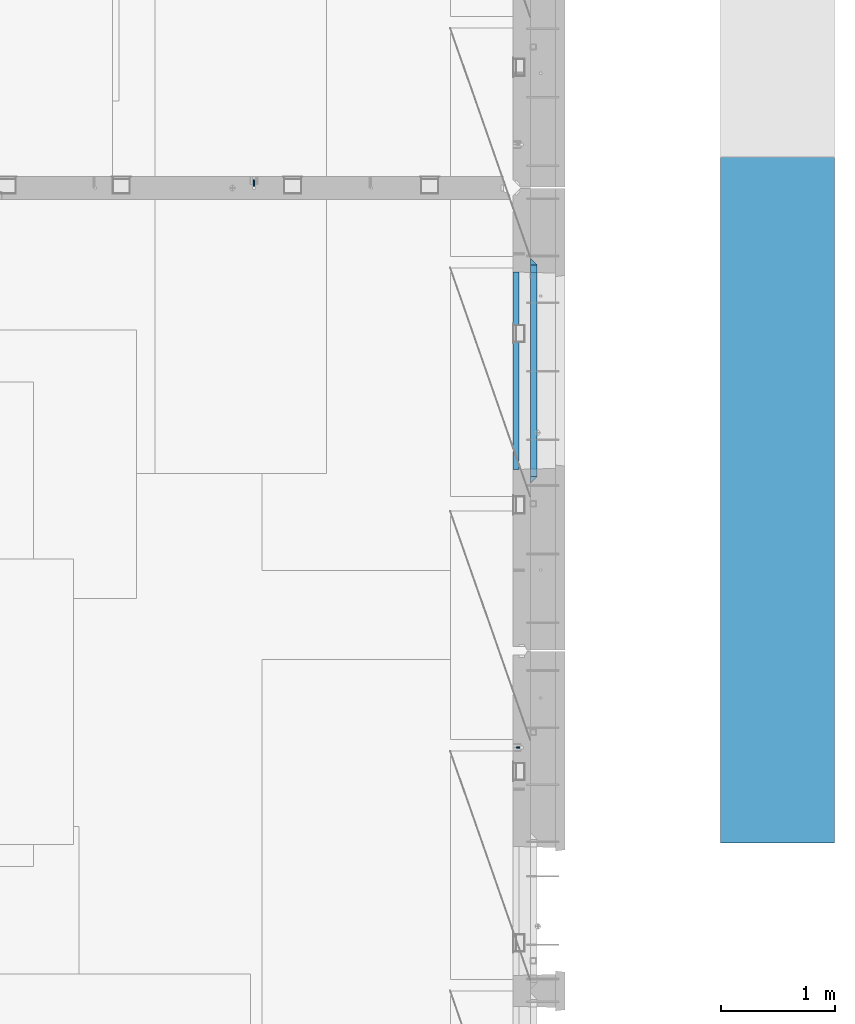
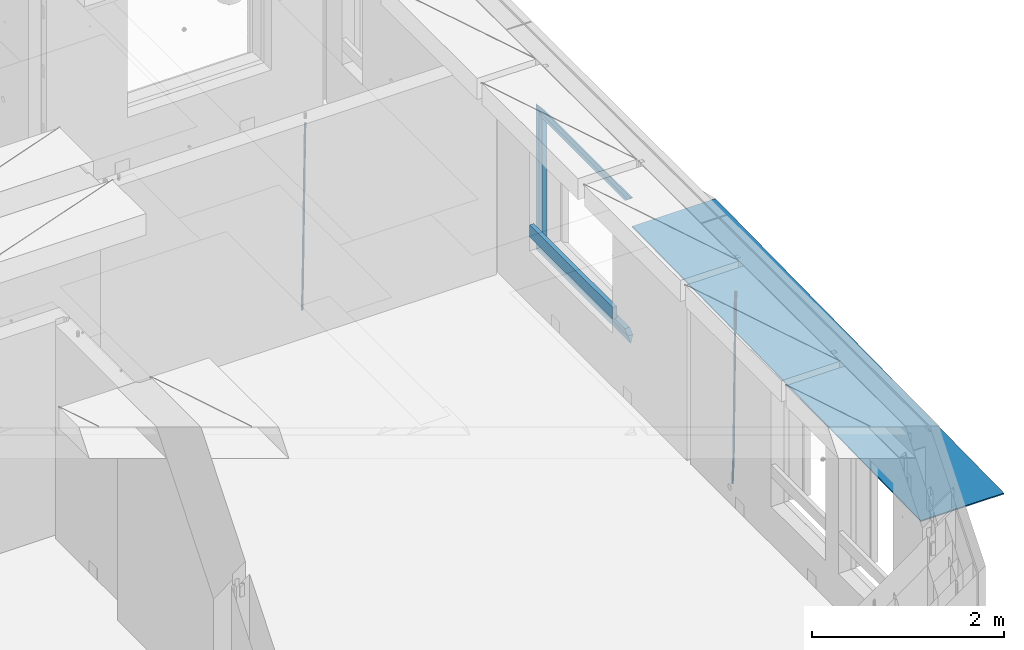
# One storey, part 114 of 325: 10 beams, 4 elements without a shape of their own.
"""IFC2X3 building model written with IfcOpenShell, lengths in millimetres."""

from ifc_helpers import new_model, si_unit, frame, origin_with_axes, place, context, subcontext, project, spatial, faceted_brep, material, type_object, element, aggregate, save


model = new_model("IFC2X3")

# Units and contexts
model_context = context("Model", 3, precision=1e-05, world=origin_with_axes())
body_context = subcontext(model_context, "Body", "Model", "MODEL_VIEW")
ifc_project = project(units=[si_unit("LENGTHUNIT", "METRE", prefix="MILLI"), si_unit("AREAUNIT", "SQUARE_METRE"), si_unit("VOLUMEUNIT", "CUBIC_METRE"), si_unit("MASSUNIT", "GRAM", prefix="KILO"), si_unit("TIMEUNIT", "SECOND"), si_unit("PLANEANGLEUNIT", "RADIAN"), si_unit("SOLIDANGLEUNIT", "STERADIAN"), si_unit("THERMODYNAMICTEMPERATUREUNIT", "DEGREE_CELSIUS"), si_unit("LUMINOUSINTENSITYUNIT", "LUMEN")], contexts=[model_context])

# Site, building, storey
site_placement = place(None, origin_with_axes())
site = spatial("IfcSite", under=ifc_project, at=site_placement, CompositionType="ELEMENT")
building_placement = place(site_placement, origin_with_axes())
building = spatial("IfcBuilding", under=site, at=building_placement, CompositionType="ELEMENT")
storey_placement = place(building_placement, origin_with_axes())
storey = spatial("IfcBuildingStorey", under=building, at=storey_placement, Name="1", CompositionType="ELEMENT", Elevation=0.0)

# Assembly, beam
assembly_1_placement = place(storey_placement, origin_with_axes())
assembly_1 = element("IfcElementAssembly", 1, at=assembly_1_placement, inside=storey, AssemblyPlace="NOTDEFINED", PredefinedType="REINFORCEMENT_UNIT")
ifc_material_1 = material()
beam_type_1 = type_object("IfcBeamType", Name="D20", PredefinedType="NOTDEFINED")
beam_1_placement = place(assembly_1_placement, frame((32639.9999999961, 17044.9997581385, 81990.0), z_axis=(0.00020576299992186, -0.999642804629538, -0.0267249099901004), x_axis=(-4.30000201928125e-08, -0.0267249099948059, 0.999642825806181)))
beam_1 = element("IfcBeam", 2, at=beam_1_placement, type_object=beam_type_1, material=ifc_material_1, Name="JM20", ObjectType="D20", context=body_context, shape_type="Brep", body=[
    faceted_brep([(0.0, -10.0, 0.0), (-4.19531716033816e-08, -7.07106781186667, -7.07106781187031), (60.4266690400545, -7.0710677960451, -7.07106780570757), (60.4266690441291, -9.99999998418934, 6.15546014159918e-09), (0.0, 0.0, -10.0), (60.426669036824, 1.58106558956206e-08, -9.99999999384454), (4.196772351861e-08, 7.07106781186303, -7.07106781186667), (60.4266690363438, 7.07106782768096, -7.07106780570757), (0.0, 10.0, 0.0), (60.4266690388904, 10.0000000158179, 6.15182216279209e-09), (4.196772351861e-08, 7.07106781185939, 7.07106781185939), (60.4266690429649, 7.07106782768096, 7.07106781802577), (0.0, 0.0, 10.0), (60.4266690461809, 1.58179318532348e-08, 10.0000000061555), (-4.19531716033816e-08, -7.07106781187031, 7.07106781185939), (60.4266690466611, -7.07106779605238, 7.07106781802213), (61.0378400410118, -7.07106779588503, -7.07106780564936), (60.991799419251, -9.99999998403655, 6.21366780251265e-09), (61.0569027789461, 1.5985278878361e-08, -9.99999999378269), (61.0378209396877, 7.07106782784831, -7.07106780564936), (60.9917724058905, 10.0000000159635, 6.21366780251265e-09), (60.9457317841297, 7.07106782781193, 7.0710678180767), (60.9266690461809, 1.59488990902901e-08, 10.0000000062028), (60.9457508854539, -7.07106779591413, 7.0710678180767), (61.6489592143771, -7.07106614513759, -7.06310863441468), (61.5568818710308, -9.9999984576425, 0.00735959856683621), (61.6870830769039, 1.71821739058942e-06, -9.99179257185824), (61.6489210170112, 7.07106947854481, -7.06310888312146), (61.556827851804, 10.0000015422847, 0.00735924683976918), (61.4647505084577, 7.07106922979438, 7.07782747982128), (61.4266266459163, 1.36643211590126e-06, 10.0065114172685), (61.464788705809, -7.07106639389531, 7.07782772852806), (176.543135720174, -7.07075579406956, -5.56673531796696), (176.451058376813, -9.99968810657447, 1.50373291501455), (176.581259582701, 0.000312069292704109, -8.49541925541052), (176.543097522794, 7.07137982961285, -5.56673556667374), (176.451004357587, 10.00031189336, 1.50373256329476), (176.35892701424, 7.07137958085514, 8.57420079627263), (176.320803151699, 0.000311717507429421, 11.5028847337162), (176.358965211621, -7.07075604281999, 8.57420104497578), (177.098753836006, -7.07075429323595, -5.55949898843028), (176.98362511232, -9.99968666800123, 1.510669025065), (177.146421932586, 0.000313595905026887, -8.48805862247536), (177.098706077581, 7.07138133041735, -5.55949936166144), (176.983557571715, 10.0003133318824, 1.51066849724157), (176.868428848029, 7.07138095712435, 8.58083651073321), (176.820760751449, 0.000313067976094317, 11.5093961447819), (176.868476606425, -7.07075466652896, 8.58083688396073), (177.654312950661, -7.07075204110879, -5.54863964998367), (177.516135294456, -9.99968450931192, 1.52107783331303), (177.711524267797, 0.000315886711177882, -8.47701274570863), (177.654255632195, 7.07138358250813, -5.54864021007961), (177.516054233929, 10.0003154905207, 1.5210770412159), (177.377876577739, 7.0713830223176, 8.59079452451624), (177.320665260588, 0.000315094497636892, 11.5191676202448), (177.377933896176, -7.07075260129932, 8.59079508461218), (299.499456785634, -7.07025810522464, -3.16697112782276), (299.361279129444, -9.99919057342777, 3.90274635547394), (299.556668102785, 0.000809822595329024, -6.09534422354773), (299.499399467197, 7.07187751838501, -3.1669716879187), (299.361198068917, 10.0008094264049, 3.90274556338045), (299.223020412712, 7.07187695819448, 10.9724630466735), (299.165809095575, 0.000809030381788034, 13.9008361423985), (299.223077731163, -7.07025866542244, 10.9724636067695), (300.03174732349, -7.07025594743027, -3.15656661289177), (299.971788958996, -9.99918809853989, 3.91467979818117), (300.056572611924, 0.000811849109595641, -6.08557274808481), (300.031722507032, 7.07187967631762, -3.15656653768019), (299.971753863239, 10.0008119014747, 3.91467990454839), (299.91179549876, 7.07187975035777, 10.9859263156177), (299.886970210311, 0.000811953817901667, 13.9149324508144), (299.911820315203, -7.0702558733974, 10.9859262404061), (300.564137759997, -7.07025623699155, -3.15794273276697), (300.582413367199, -9.99918843065097, 3.91310145956595), (300.556570941641, 0.000811577163403854, -6.0868651410201), (300.564145451674, 7.07187938674906, -3.15794274158179), (300.582424244858, 10.0008115693345, 3.91310144710224), (300.600699852032, 7.07187937566778, 10.9841456394352), (300.608266670402, 0.000811561512819026, 13.9130680476919), (300.600692160384, -7.07025624805829, 10.98414564825), (2294.16589219622, -7.0713405251372, -8.31099358700158), (2294.1841678034, -10.0002727187966, -1.23994939466866), (2294.15832537785, -0.000272710982244462, -11.2399159952547), (2294.16589988787, 7.07079509858886, -8.31099359582004), (2294.18417868105, 9.99972728118883, -1.23994940713601), (2294.20245428824, 7.07079508752213, 5.83109478519327), (2294.2100211066, -0.00027272663282929, 8.76001719345368), (2294.20244659658, -7.07134053620393, 5.83109479401173), (2294.7782683276, -7.07134085819416, -8.31257645345977), (2294.72126025338, -10.000273010919, -1.24133766827799), (2294.84007459224, -0.000273081772320438, -11.2416781768807), (2294.87047377572, 7.07079471537872, -8.31281477453012), (2294.85165844864, 9.9997269181622, -1.24167470516841), (2294.7946503744, 7.07079476544459, 5.82956408001337), (2294.73284410976, -0.000273010977252852, 8.75866580342336), (2294.7024449263, -7.07134080815013, 5.82980240107645), (2295.39054023061, -7.0793250091956, -8.30442771922026), (2295.25826128852, -10.0072756143927, -1.23419071494573), (2295.52170777075, -0.00916171800054144, -11.2326063125765), (2295.57492774284, 7.06160849139269, -8.30343918807193), (2295.51902460904, 9.99102432676591, -1.23279272078435), (2295.38674566693, 7.06307372157607, 5.83744428349019), (2295.25557812679, -0.0070895696117077, 8.76562287684646), (2295.20235815471, -7.07785977901949, 5.83645575234186), (2317.1947101649, -7.36365585014573, -8.01423575520312), (2317.06243122277, -10.2916064553428, -0.94399875092131), (2317.32587770502, -0.293492558957951, -10.9424143485521), (2317.37909767711, 6.77727765044983, -8.01324722405116), (2317.32319454331, 9.70669348581578, -0.942600756767206), (2317.1909156012, 6.77874288063322, 6.12763624751096), (2317.05974806109, -0.291420410569117, 9.0558148408636), (2317.00652808898, -7.36219061996962, 6.12664771636264), (2317.83015404257, -7.37194216843636, -8.00577862486898), (2317.72252095213, -10.300214160583, -0.935213608652703), (2317.90419832576, -0.301033978277701, -10.9347174723516), (2317.90127966482, 6.77046829039318, -8.00629749759901), (2317.82310777172, 9.70017451494641, -0.935947405505431), (2317.71547468127, 6.77190252279979, 6.13461761071085), (2317.64143039809, -0.29900566735887, 9.06355645819713), (2317.64434905903, -7.37050793602975, 6.13513648344451), (2318.46565174212, -7.3700661537805, -7.99751648408346), (2318.38266643914, -10.2982456018653, -0.926623872735945), (2318.48256818345, -0.299336209594912, -10.9272153854981), (2318.42350634121, 6.77200652527245, -7.99954269419686), (2318.32306384158, 9.70166538090416, -0.929489366557391), (2318.2400785386, 6.77348593281204, 6.14140324480104), (2318.22316209726, -0.297244011366274, 9.07110214621207), (2318.2822239395, -7.36858674623363, 6.1434294549108), (2418.48643733139, -7.07180401323421, -6.70013846199799), (2418.4034520284, -9.99998346132634, 0.370754149349523), (2418.5033537727, -0.00107406904135132, -9.62983736341266), (2418.44429193046, 7.07026866581873, -6.70216467211139), (2418.34384943081, 9.99992752145772, 0.367888655531715), (2418.26086412782, 7.0717480733656, 7.43878126688651), (2418.24394768651, 0.00101812917273492, 10.3684801682975), (2418.30300952874, -7.07032460568735, 7.44080747699627)], [[[0, 1, 2, 3]], [[1, 4, 5, 2]], [[4, 6, 7, 5]], [[6, 8, 9, 7]], [[8, 10, 11, 9]], [[10, 12, 13, 11]], [[12, 14, 15, 13]], [[14, 0, 3, 15]], [[14, 12, 10, 8, 6, 4, 1, 0]], [[3, 2, 16, 17]], [[2, 5, 18, 16]], [[5, 7, 19, 18]], [[7, 9, 20, 19]], [[9, 11, 21, 20]], [[11, 13, 22, 21]], [[13, 15, 23, 22]], [[15, 3, 17, 23]], [[17, 16, 24, 25]], [[16, 18, 26, 24]], [[18, 19, 27, 26]], [[19, 20, 28, 27]], [[20, 21, 29, 28]], [[21, 22, 30, 29]], [[22, 23, 31, 30]], [[23, 17, 25, 31]], [[25, 24, 32, 33]], [[24, 26, 34, 32]], [[26, 27, 35, 34]], [[27, 28, 36, 35]], [[28, 29, 37, 36]], [[29, 30, 38, 37]], [[30, 31, 39, 38]], [[31, 25, 33, 39]], [[33, 32, 40, 41]], [[32, 34, 42, 40]], [[34, 35, 43, 42]], [[35, 36, 44, 43]], [[36, 37, 45, 44]], [[37, 38, 46, 45]], [[38, 39, 47, 46]], [[39, 33, 41, 47]], [[41, 40, 48, 49]], [[40, 42, 50, 48]], [[42, 43, 51, 50]], [[43, 44, 52, 51]], [[44, 45, 53, 52]], [[45, 46, 54, 53]], [[46, 47, 55, 54]], [[47, 41, 49, 55]], [[49, 48, 56, 57]], [[48, 50, 58, 56]], [[50, 51, 59, 58]], [[51, 52, 60, 59]], [[52, 53, 61, 60]], [[53, 54, 62, 61]], [[54, 55, 63, 62]], [[55, 49, 57, 63]], [[57, 56, 64, 65]], [[56, 58, 66, 64]], [[58, 59, 67, 66]], [[59, 60, 68, 67]], [[60, 61, 69, 68]], [[61, 62, 70, 69]], [[62, 63, 71, 70]], [[63, 57, 65, 71]], [[65, 64, 72, 73]], [[64, 66, 74, 72]], [[66, 67, 75, 74]], [[67, 68, 76, 75]], [[68, 69, 77, 76]], [[69, 70, 78, 77]], [[70, 71, 79, 78]], [[71, 65, 73, 79]], [[73, 72, 80, 81]], [[72, 74, 82, 80]], [[74, 75, 83, 82]], [[75, 76, 84, 83]], [[76, 77, 85, 84]], [[77, 78, 86, 85]], [[78, 79, 87, 86]], [[79, 73, 81, 87]], [[81, 80, 88, 89]], [[80, 82, 90, 88]], [[82, 83, 91, 90]], [[83, 84, 92, 91]], [[84, 85, 93, 92]], [[85, 86, 94, 93]], [[86, 87, 95, 94]], [[87, 81, 89, 95]], [[89, 88, 96, 97]], [[88, 90, 98, 96]], [[90, 91, 99, 98]], [[91, 92, 100, 99]], [[92, 93, 101, 100]], [[93, 94, 102, 101]], [[94, 95, 103, 102]], [[95, 89, 97, 103]], [[97, 96, 104, 105]], [[96, 98, 106, 104]], [[98, 99, 107, 106]], [[99, 100, 108, 107]], [[100, 101, 109, 108]], [[101, 102, 110, 109]], [[102, 103, 111, 110]], [[103, 97, 105, 111]], [[105, 104, 112, 113]], [[104, 106, 114, 112]], [[106, 107, 115, 114]], [[107, 108, 116, 115]], [[108, 109, 117, 116]], [[109, 110, 118, 117]], [[110, 111, 119, 118]], [[111, 105, 113, 119]], [[113, 112, 120, 121]], [[112, 114, 122, 120]], [[114, 115, 123, 122]], [[115, 116, 124, 123]], [[116, 117, 125, 124]], [[117, 118, 126, 125]], [[118, 119, 127, 126]], [[119, 113, 121, 127]], [[121, 120, 128, 129]], [[120, 122, 130, 128]], [[122, 123, 131, 130]], [[123, 124, 132, 131]], [[124, 125, 133, 132]], [[125, 126, 134, 133]], [[126, 127, 135, 134]], [[127, 121, 129, 135]], [[130, 131, 132, 133, 134, 135, 129, 128]]]),
])
aggregate(assembly_1, [beam_1])

assembly_2_placement = place(storey_placement, origin_with_axes())
assembly_2 = element("IfcElementAssembly", 3, at=assembly_2_placement, inside=storey, AssemblyPlace="NOTDEFINED", PredefinedType="REINFORCEMENT_UNIT")
beam_2_placement = place(assembly_2_placement, frame((34944.9999977209, 12080.9402860984, 81990.0), z_axis=(0.999642804629538, 0.000205762999925497, -0.0267249099901003), x_axis=(0.0267249109941254, -4.30000210532798e-08, 0.999642825779465)))
beam_2 = element("IfcBeam", 4, at=beam_2_placement, type_object=beam_type_1, material=ifc_material_1, Name="JM20", ObjectType="D20", context=body_context, shape_type="Brep", body=[
    faceted_brep([(0.0, -10.0, 0.0), (-4.19531716033816e-08, -7.07106781186667, -7.07106781187031), (60.4266690400545, -7.0710677960451, -7.07106780570757), (60.4266690441291, -9.99999998418934, 6.15546014159918e-09), (0.0, 0.0, -10.0), (60.426669036824, 1.58106558956206e-08, -9.99999999384454), (4.196772351861e-08, 7.07106781186303, -7.07106781186667), (60.4266690363438, 7.07106782768096, -7.07106780570757), (0.0, 10.0, 0.0), (60.4266690388904, 10.0000000158179, 6.15182216279209e-09), (4.196772351861e-08, 7.07106781185939, 7.07106781185939), (60.4266690429649, 7.07106782768096, 7.07106781802577), (0.0, 0.0, 10.0), (60.4266690461809, 1.58179318532348e-08, 10.0000000061555), (-4.19531716033816e-08, -7.07106781187031, 7.07106781185939), (60.4266690466611, -7.07106779605238, 7.07106781802213), (61.0378400410118, -7.07106779588503, -7.07106780564936), (60.991799419251, -9.99999998403655, 6.21366780251265e-09), (61.0569027789461, 1.5985278878361e-08, -9.99999999378269), (61.0378209396877, 7.07106782784831, -7.07106780564936), (60.9917724058905, 10.0000000159635, 6.21366780251265e-09), (60.9457317841297, 7.07106782781193, 7.0710678180767), (60.9266690461809, 1.59488990902901e-08, 10.0000000062028), (60.9457508854539, -7.07106779591413, 7.0710678180767), (61.6489592143771, -7.07106614513759, -7.06310863441468), (61.5568818710308, -9.9999984576425, 0.00735959856683621), (61.6870830769039, 1.71821739058942e-06, -9.99179257185824), (61.6489210170112, 7.07106947854481, -7.06310888312146), (61.556827851804, 10.0000015422847, 0.00735924683976918), (61.4647505084577, 7.07106922979438, 7.07782747982128), (61.4266266459163, 1.36643211590126e-06, 10.0065114172685), (61.464788705809, -7.07106639389531, 7.07782772852806), (176.543135720174, -7.07075579406956, -5.56673531796696), (176.451058376813, -9.99968810657447, 1.50373291501455), (176.581259582701, 0.000312069292704109, -8.49541925541052), (176.543097522794, 7.07137982961285, -5.56673556667374), (176.451004357587, 10.00031189336, 1.50373256329476), (176.35892701424, 7.07137958085514, 8.57420079627263), (176.320803151699, 0.000311717507429421, 11.5028847337162), (176.358965211621, -7.07075604281999, 8.57420104497578), (177.098753836006, -7.07075429323595, -5.55949898843028), (176.98362511232, -9.99968666800123, 1.510669025065), (177.146421932586, 0.000313595905026887, -8.48805862247536), (177.098706077581, 7.07138133041735, -5.55949936166144), (176.983557571715, 10.0003133318824, 1.51066849724157), (176.868428848029, 7.07138095712435, 8.58083651073321), (176.820760751449, 0.000313067976094317, 11.5093961447819), (176.868476606425, -7.07075466652896, 8.58083688396073), (177.654312950661, -7.07075204110879, -5.54863964998367), (177.516135294456, -9.99968450931192, 1.52107783331303), (177.711524267797, 0.000315886711177882, -8.47701274570863), (177.654255632195, 7.07138358250813, -5.54864021007961), (177.516054233929, 10.0003154905207, 1.5210770412159), (177.377876577739, 7.0713830223176, 8.59079452451624), (177.320665260588, 0.000315094497636892, 11.5191676202448), (177.377933896176, -7.07075260129932, 8.59079508461218), (299.436796249574, -7.07025836271714, -3.1681962331204), (299.298618593355, -9.99919083092027, 3.90152125031091), (299.494007566798, 0.000809565110102994, -6.09656932889993), (299.436738931283, 7.07187726089978, -3.16819679320906), (299.298537533061, 10.0008091689197, 3.90152045822106), (299.160359876842, 7.07187670072017, 10.9712379416487), (299.103148559603, 0.000808772889286047, 13.8996110374392), (299.160417195119, -7.07025892290039, 10.9712385017483), (299.98743051647, -7.07025613056248, -3.15743315966392), (299.971788958996, -9.99918809853989, 3.91467979818117), (299.993912075952, 0.000811591617093654, -6.08679785393178), (299.987423933868, 7.07187949325817, -3.1574327280432), (299.971753863239, 10.0008119014747, 3.91467990454839), (299.95611230444, 7.07187992653053, 10.9867922621015), (299.949630744944, 0.000812204350950196, 13.9161569563694), (299.956118887014, -7.07025569729012, 10.9867918304735), (300.538107039494, -7.07025785017686, -3.16575821840888), (300.644985195438, -9.99919020432935, 3.90450175465594), (300.493854948218, 0.000810030429420294, -6.09435592770024), (300.538151196495, 7.071877773491, -3.16575855385963), (300.645047642858, 10.0008097955724, 3.90450128024895), (300.751925798773, 7.07187744142357, 10.9747612533101), (300.796177890064, 0.000809560813650023, 13.9033589625978), (300.751881641787, -7.07025818224065, 10.9747615887682), (2293.36490490142, -7.07648090940347, -33.2930642912361), (2293.47178305736, -10.0054132635523, -26.2228043181785), (2293.32065281013, -0.00541302880083094, -36.2216620005347), (2293.36494905842, 7.06565471425711, -33.2930646266868), (2293.47184550477, 9.99458673634581, -26.2228047925819), (2293.57872366071, 7.06565438219332, -19.1525448195243), (2293.62297575199, -0.00541349841296324, -16.2239471102366), (2293.57867950371, -7.0764812414709, -19.1525444840736), (2294.0658245362, -7.07648309818615, -33.3036607065333), (2294.05312277409, -10.0054150789219, -26.2315929392535), (2294.10928714235, -0.00541549149056664, -36.2335844756526), (2294.15805078732, 7.06565223761572, -33.3050546393533), (2294.18355038921, 9.99458451388637, -26.2335642579346), (2294.17084862708, 7.06565253314329, -19.1614964906439), (2294.12738602093, -0.00541507354500936, -16.2315727215355), (2294.07862237596, -7.07648280265857, -19.1601025578348), (2294.76670261032, -7.08562269121467, -33.294332712383), (2294.63442802057, -10.0129954178956, -26.2238563411993), (2294.89787471293, -0.0156988342423574, -36.2230891548279), (2294.95110548967, 7.05531064255774, -33.2944998654275), (2294.89521307347, 9.98530428734011, -26.2240927312887), (2294.76293848372, 7.0579315606592, -19.1536163601049), (2294.63176638114, -0.0119922963167483, -16.2248599176673), (2294.57853560438, -7.08300177311321, -19.1534492070678), (2316.52657204497, -7.36937582653991, -33.0047303660212), (2316.39429745522, -10.2967485532172, -25.9342539948302), (2316.65774414754, -0.299451969567599, -35.9334868084661), (2316.7109749243, 6.7715575072325, -33.0048975190657), (2316.65508250811, 9.70155115201487, -25.9344903849269), (2316.52280791836, 6.7741784253376, -18.8640140137468), (2316.39163581574, -0.295745431634714, -15.9352575713092), (2316.33840503903, -7.36675490843481, -18.863846860706), (2317.16202064224, -7.37766220584308, -32.9962731735213), (2317.05438744847, -10.3053562613532, -25.9254688497131), (2317.23607125619, -0.306993473008333, -35.925789846493), (2317.23316144495, 6.76474808850253, -32.9979477328052), (2317.15499573652, 9.6950321815566, -25.9278370341635), (2317.04736254275, 6.7673381260538, -18.8570327103698), (2316.97331192881, -0.303330606784584, -15.9275160373909), (2316.97622174003, -7.37507216829545, -18.8553581510787), (2317.79752306276, -7.37578610372293, -32.9880110666527), (2317.71453320107, -10.3033876998124, -25.9168792378296), (2317.81444760226, -0.305295583297266, -35.918287695793), (2317.75539265381, 6.76628640723357, -32.9911928173897), (2317.65495180529, 9.69652304524061, -25.9213789128698), (2317.5719619436, 6.76892144914746, -18.8502470840467), (2317.55503740412, -0.301569071270933, -15.9199704549137), (2317.61409235255, -7.3731510618054, -18.847065333317), (2417.8183084176, -7.07752398473531, -31.6906369377139), (2417.73531855589, -10.0051255808248, -24.6195051088798), (2417.83523295709, -0.007033464313281, -34.6209135668432), (2417.77617800863, 7.06454852621755, -31.6938186884508), (2417.67573716014, 9.99478516423187, -24.6240047839383), (2417.59274729842, 7.06718356813872, -17.5528729551006), (2417.57582275895, -0.00330695228694822, -14.6225963259749), (2417.6348777074, -7.07488894281778, -17.5496912043673)], [[[0, 1, 2, 3]], [[1, 4, 5, 2]], [[4, 6, 7, 5]], [[6, 8, 9, 7]], [[8, 10, 11, 9]], [[10, 12, 13, 11]], [[12, 14, 15, 13]], [[14, 0, 3, 15]], [[14, 12, 10, 8, 6, 4, 1, 0]], [[3, 2, 16, 17]], [[2, 5, 18, 16]], [[5, 7, 19, 18]], [[7, 9, 20, 19]], [[9, 11, 21, 20]], [[11, 13, 22, 21]], [[13, 15, 23, 22]], [[15, 3, 17, 23]], [[17, 16, 24, 25]], [[16, 18, 26, 24]], [[18, 19, 27, 26]], [[19, 20, 28, 27]], [[20, 21, 29, 28]], [[21, 22, 30, 29]], [[22, 23, 31, 30]], [[23, 17, 25, 31]], [[25, 24, 32, 33]], [[24, 26, 34, 32]], [[26, 27, 35, 34]], [[27, 28, 36, 35]], [[28, 29, 37, 36]], [[29, 30, 38, 37]], [[30, 31, 39, 38]], [[31, 25, 33, 39]], [[33, 32, 40, 41]], [[32, 34, 42, 40]], [[34, 35, 43, 42]], [[35, 36, 44, 43]], [[36, 37, 45, 44]], [[37, 38, 46, 45]], [[38, 39, 47, 46]], [[39, 33, 41, 47]], [[41, 40, 48, 49]], [[40, 42, 50, 48]], [[42, 43, 51, 50]], [[43, 44, 52, 51]], [[44, 45, 53, 52]], [[45, 46, 54, 53]], [[46, 47, 55, 54]], [[47, 41, 49, 55]], [[49, 48, 56, 57]], [[48, 50, 58, 56]], [[50, 51, 59, 58]], [[51, 52, 60, 59]], [[52, 53, 61, 60]], [[53, 54, 62, 61]], [[54, 55, 63, 62]], [[55, 49, 57, 63]], [[57, 56, 64, 65]], [[56, 58, 66, 64]], [[58, 59, 67, 66]], [[59, 60, 68, 67]], [[60, 61, 69, 68]], [[61, 62, 70, 69]], [[62, 63, 71, 70]], [[63, 57, 65, 71]], [[65, 64, 72, 73]], [[64, 66, 74, 72]], [[66, 67, 75, 74]], [[67, 68, 76, 75]], [[68, 69, 77, 76]], [[69, 70, 78, 77]], [[70, 71, 79, 78]], [[71, 65, 73, 79]], [[73, 72, 80, 81]], [[72, 74, 82, 80]], [[74, 75, 83, 82]], [[75, 76, 84, 83]], [[76, 77, 85, 84]], [[77, 78, 86, 85]], [[78, 79, 87, 86]], [[79, 73, 81, 87]], [[81, 80, 88, 89]], [[80, 82, 90, 88]], [[82, 83, 91, 90]], [[83, 84, 92, 91]], [[84, 85, 93, 92]], [[85, 86, 94, 93]], [[86, 87, 95, 94]], [[87, 81, 89, 95]], [[89, 88, 96, 97]], [[88, 90, 98, 96]], [[90, 91, 99, 98]], [[91, 92, 100, 99]], [[92, 93, 101, 100]], [[93, 94, 102, 101]], [[94, 95, 103, 102]], [[95, 89, 97, 103]], [[97, 96, 104, 105]], [[96, 98, 106, 104]], [[98, 99, 107, 106]], [[99, 100, 108, 107]], [[100, 101, 109, 108]], [[101, 102, 110, 109]], [[102, 103, 111, 110]], [[103, 97, 105, 111]], [[105, 104, 112, 113]], [[104, 106, 114, 112]], [[106, 107, 115, 114]], [[107, 108, 116, 115]], [[108, 109, 117, 116]], [[109, 110, 118, 117]], [[110, 111, 119, 118]], [[111, 105, 113, 119]], [[113, 112, 120, 121]], [[112, 114, 122, 120]], [[114, 115, 123, 122]], [[115, 116, 124, 123]], [[116, 117, 125, 124]], [[117, 118, 126, 125]], [[118, 119, 127, 126]], [[119, 113, 121, 127]], [[121, 120, 128, 129]], [[120, 122, 130, 128]], [[122, 123, 131, 130]], [[123, 124, 132, 131]], [[124, 125, 133, 132]], [[125, 126, 134, 133]], [[126, 127, 135, 134]], [[127, 121, 129, 135]], [[130, 131, 132, 133, 134, 135, 129, 128]]]),
])
aggregate(assembly_2, [beam_2])

# Assembly, beams
assembly_3_placement = place(storey_placement, origin_with_axes())
assembly_3 = element("IfcElementAssembly", 5, at=assembly_3_placement, inside=storey, AssemblyPlace="NOTDEFINED", PredefinedType="REINFORCEMENT_UNIT")
ifc_material_2 = material(Name="TIMBER/T24")
beam_type_2 = type_object("IfcBeamType", PredefinedType="NOTDEFINED")
beam_3_placement = place(assembly_3_placement, frame((34935.0002758707, 14515.0011884524, 82685.0), z_axis=(0.0, 0.0, 1.0), x_axis=(0.0, 1.0, 0.0)))
beam_3 = element("IfcBeam", 6, at=beam_3_placement, type_object=beam_type_2, material=ifc_material_2, context=body_context, shape_type="Brep", body=[
    faceted_brep([(-3.63797880709171e-12, 24.9999999999964, -75.0), (-3.63797880709171e-12, 24.9999999999964, 75.0), (1730.0, 25.0, 75.0), (1730.0, 25.0, -75.0), (0.0, -25.0000000000073, 75.0), (1730.0, -25.0, 75.0), (0.0, -25.0000000000073, -75.0), (1730.0, -25.0, -75.0)], [[[0, 1, 2, 3]], [[1, 4, 5, 2]], [[4, 6, 7, 5]], [[6, 0, 3, 7]], [[5, 7, 3, 2]], [[6, 4, 1, 0]]]),
])
ifc_material_3 = material(Name="CONCRETE/C25/30")
beam_type_3 = type_object("IfcBeamType", PredefinedType="NOTDEFINED")
beam_4_placement = place(assembly_3_placement, frame((35090.0, 14394.9995850056, 84145.0), z_axis=(0.0, 0.0, -1.0), x_axis=(0.0, 1.0, 0.0)))
beam_4 = element("IfcBeam", 7, at=beam_4_placement, type_object=beam_type_3, material=ifc_material_3, Name="SK", context=body_context, shape_type="Brep", body=[
    faceted_brep([(60.0000000000073, 30.0, 30.0), (0.0, -30.0, -30.0), (60.0000000000073, -30.0, 30.0), (1910.00076293945, 30.0, 30.0), (1970.00076293945, -30.0, -30.0), (1910.00076293945, -30.0, 30.0)], [[[0, 1, 2]], [[1, 0, 3, 4]], [[2, 1, 4, 5]], [[0, 2, 5, 3]], [[4, 3, 5]]]),
])
beam_5_placement = place(assembly_3_placement, frame((35090.0, 14454.9995850056, 84085.0), z_axis=(0.0, 0.0, -1.0), x_axis=(0.0, 1.0, 0.0)))
beam_5 = element("IfcBeam", 8, at=beam_5_placement, type_object=beam_type_3, material=ifc_material_3, Name="SK", context=body_context, shape_type="Brep", body=[
    faceted_brep([(1785.9467088854, -30.0, 24.0540540540533), (1784.32508726378, 30.0, 25.6756756756804), (65.6764386151262, 30.0, 25.6756756756804), (64.0548169935064, -30.0, 24.0540540540533), (65.6764386151262, 30.0, 26.294090229203), (64.0548169935064, -30.0, 24.9041288395529), (0.0, 30.0, -30.0), (0.0, -30.0, -30.0), (1850.00076293945, 30.0, -30.0), (1850.00076293945, -30.0, -30.0), (1785.9467088854, -30.0, 24.9034748914128), (1784.32508726378, 30.0, 26.2934362810774)], [[[0, 1, 2, 3]], [[3, 2, 4, 5]], [[5, 4, 6, 7]], [[7, 6, 8, 9]], [[0, 3, 5, 7, 9, 10]], [[1, 0, 10, 11]], [[6, 4, 2, 1, 11, 8]], [[9, 8, 11, 10]]]),
])
beam_6_placement = place(assembly_3_placement, frame((35090.0, 16335.0003479451, 84175.0), z_axis=(0.0, -1.0, 0.0), x_axis=(0.0, 0.0, -1.0)))
beam_6 = element("IfcBeam", 9, at=beam_6_placement, type_object=beam_type_3, material=ifc_material_3, Name="SK", context=body_context, shape_type="Brep", body=[
    faceted_brep([(60.0000000000073, 30.0, 30.0), (0.0, -30.0, -30.0), (60.0000000000073, -30.0, 30.0), (1795.00000000001, 30.0, 30.0), (1855.0, -30.0, -30.0), (1795.00000000001, -30.0, 30.0)], [[[0, 1, 2]], [[3, 4, 1, 0]], [[4, 5, 2, 1]], [[5, 3, 0, 2]], [[5, 4, 3]]]),
])
beam_7_placement = place(assembly_3_placement, frame((35090.0, 16305.0003479451, 82410.0), z_axis=(0.0, 0.0, 1.0), x_axis=(0.0, -1.0, 0.0)))
beam_7 = element("IfcBeam", 10, at=beam_7_placement, type_object=beam_type_3, material=ifc_material_3, Name="SK", context=body_context, shape_type="Brep", body=[
    faceted_brep([(1785.94594594595, -30.0, 24.0540540540533), (1784.32432432433, 30.0, 25.6756756756804), (65.6756756756768, 30.0, 25.6756756756804), (64.0540540540533, -30.0, 24.0540540540533), (1785.94594594595, -30.0, 24.9041288395238), (1784.32432432433, 30.0, 26.2940902291739), (1850.00076293945, -30.0, -30.0), (1850.00076293945, 30.0, -30.0), (0.0, 30.0, -30.0), (65.6756756756768, 30.0, 26.293436281092), (64.0540540540533, -30.0, 24.9034748914419), (0.0, -30.0, -30.0)], [[[0, 1, 2, 3]], [[1, 0, 4, 5]], [[4, 6, 7, 5]], [[2, 1, 5, 7, 8, 9]], [[3, 2, 9, 10]], [[6, 4, 0, 3, 10, 11]], [[11, 8, 7, 6]], [[11, 10, 9, 8]]]),
])
beam_8_placement = place(assembly_3_placement, frame((35090.0, 16365.0003479451, 82350.0), z_axis=(0.0, 0.0, 1.0), x_axis=(0.0, -1.0, 0.0)))
beam_8 = element("IfcBeam", 11, at=beam_8_placement, type_object=beam_type_3, material=ifc_material_3, Name="SK", context=body_context, shape_type="Brep", body=[
    faceted_brep([(1970.00076293945, -30.0, -30.0), (1910.00076293945, 30.0, 30.0), (1910.00076293945, -30.0, 30.0), (60.0000000000073, 30.0, 30.0), (60.0000000000073, -30.0, 30.0), (0.0, -30.0, -30.0)], [[[0, 1, 2]], [[3, 4, 2, 1]], [[4, 5, 0, 2]], [[5, 3, 1, 0]], [[3, 5, 4]]]),
])
beam_type_4 = type_object("IfcBeamType", PredefinedType="NOTDEFINED")
beam_9_placement = place(assembly_3_placement, frame((35090.0, 16270.0003479451, 84115.0), z_axis=(0.0, -1.0, 0.0), x_axis=(0.0, 0.0, -1.0)))
beam_9 = element("IfcBeam", 12, at=beam_9_placement, type_object=beam_type_4, material=ifc_material_3, Name="SK", context=body_context, shape_type="Brep", body=[
    faceted_brep([(0.0, -30.0, -35.0), (54.9034748914273, -30.0, 29.0540540540533), (56.2934362811066, 30.0, 30.6756756756768), (0.0, 30.0, -35.0), (1735.0, 30.0, -35.0), (1735.0, -30.0, -35.0), (1680.09652510857, -30.0, 29.0540540540533), (1678.70656371891, 30.0, 30.6756756756768)], [[[0, 1, 2, 3]], [[4, 5, 0, 3]], [[1, 0, 5, 6]], [[2, 1, 6, 7]], [[3, 2, 7, 4]], [[5, 4, 7, 6]]]),
])
aggregate(assembly_3, [beam_3, beam_4, beam_5, beam_6, beam_9, beam_7, beam_8])

# Assembly, beam
assembly_4_placement = place(storey_placement, origin_with_axes())
assembly_4 = element("IfcElementAssembly", 13, at=assembly_4_placement, inside=storey, Name="Steel Assembly", AssemblyPlace="NOTDEFINED", PredefinedType="NOTDEFINED")
ifc_material_4 = material()
beam_type_5 = type_object("IfcBeamType", PredefinedType="NOTDEFINED")
beam_10_placement = place(assembly_4_placement, frame((37224.9964796872, 17250.1251292524, 81492.501040236), z_axis=(1.0, 0.0, 0.0), x_axis=(0.0, -0.999861301864686, -0.0166546399977453)))
beam_10 = element("IfcBeam", 14, at=beam_10_placement, type_object=beam_type_5, material=ifc_material_4, context=body_context, shape_type="Brep", body=[
    faceted_brep([(0.0, 7.5, -500.0), (0.0, 7.5, 500.0), (6004.33278974442, 7.5, 500.0), (6004.33278974442, 7.5, -500.0), (0.0, -7.5, 500.0), (6004.33278974442, -7.5, 500.0), (0.0, -7.5, -500.0), (6004.33278974442, -7.5, -500.0)], [[[0, 1, 2, 3]], [[1, 4, 5, 2]], [[4, 6, 7, 5]], [[6, 0, 3, 7]], [[5, 7, 3, 2]], [[6, 4, 1, 0]]]),
])
aggregate(assembly_4, [beam_10])

save(model, "model.ifc")
